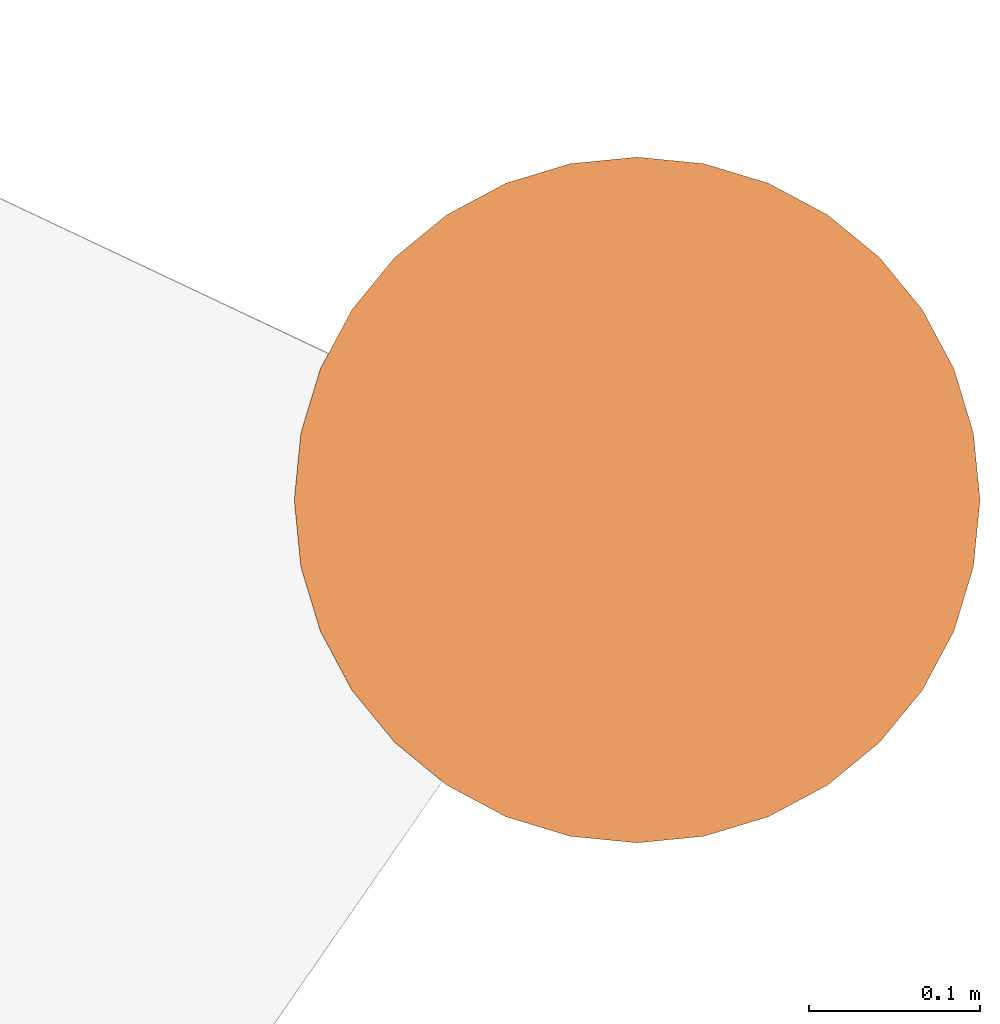
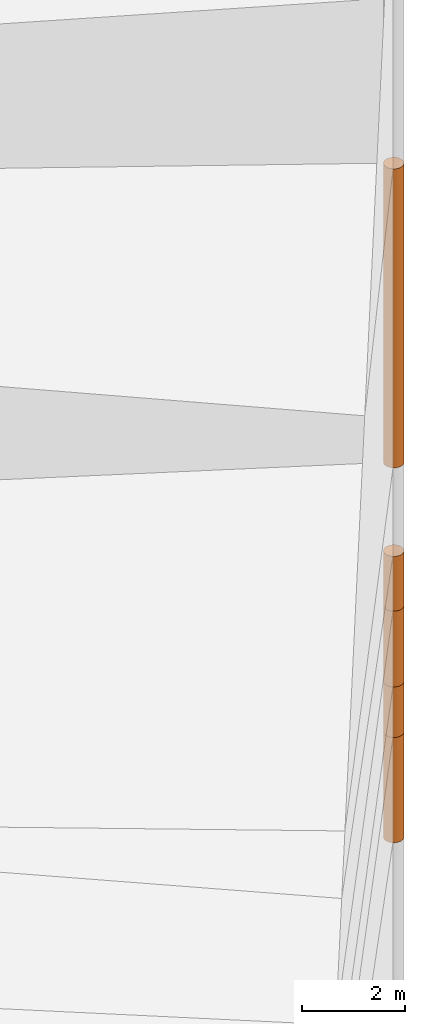
# One storey, part 19 of 24: 5 geographic elements.
"""IFC4 building model written with IfcOpenShell, lengths in metres."""

from ifc_helpers import new_model, entity, si_unit, converted_unit, frame, origin_with_axes, origin_2d_with_axis, place, context, subcontext, project, spatial, polygons, element, save


model = new_model("IFC4")

# Units and contexts
model_context = context("Model", 3, precision=1e-05, world=origin_with_axes())
plan_context = context("Plan", 2, precision=1e-05, world=origin_2d_with_axis())
body_context = subcontext(model_context, "Body", "Model", "MODEL_VIEW")
ifc_project = project(units=[converted_unit("PLANEANGLEUNIT", "degree", entity("IfcReal", 0.0174532925199433), si_unit("PLANEANGLEUNIT", "RADIAN"), dimensions=[0, 0, 0, 0, 0, 0, 0]), si_unit("AREAUNIT", "SQUARE_METRE"), si_unit("VOLUMEUNIT", "CUBIC_METRE"), si_unit("LENGTHUNIT", "METRE")], contexts=[model_context, plan_context])

# Site, building, storey
site_placement = place(None, origin_with_axes())
site = spatial("IfcSite", under=ifc_project, at=site_placement)
building_placement = place(site_placement, origin_with_axes())
building = spatial("IfcBuilding", under=site, at=building_placement, Name="Building")
storey_placement = place(building_placement, origin_with_axes())
storey = spatial("IfcBuildingStorey", under=building, at=storey_placement, Name="Storey")

# Geographic elements
geographic_element_1_placement = place(storey_placement, frame((50.0999984741211, 76.4000015258789, -8.74999904632568), z_axis=(0.0, 0.0, 1.0), x_axis=(1.0, 0.0, 0.0)))
element("IfcGeographicElement", 1, at=geographic_element_1_placement, inside=storey, PredefinedType="NOTDEFINED", context=body_context, shape_type="Tessellation", body=[
    polygons([(0.0, 0.0, -1.24999988079071), (0.0390180610120296, 0.196157038211823, -1.24999988079071), (0.0, 0.199999988079071, -1.24999988079071), (0.0, 0.0, 1.24999988079071), (0.0, 0.199999988079071, 1.24999988079071), (0.0390180610120296, 0.196157038211823, 1.24999988079071), (0.0765366926789284, 0.18477588891983, -1.24999988079071), (0.0765366926789284, 0.18477588891983, 1.24999988079071), (0.111114047467709, 0.166293919086456, -1.24999988079071), (0.111114047467709, 0.166293919086456, 1.24999988079071), (0.141421362757683, 0.141421362757683, -1.24999988079071), (0.141421362757683, 0.141421362757683, 1.24999988079071), (0.166293919086456, 0.111114047467709, -1.24999988079071), (0.166293919086456, 0.111114047467709, 1.24999988079071), (0.18477588891983, 0.0765366926789284, -1.24999988079071), (0.18477588891983, 0.0765366926789284, 1.24999988079071), (0.196157038211823, 0.0390180610120296, -1.24999988079071), (0.196157038211823, 0.0390180610120296, 1.24999988079071), (0.199999988079071, 0.0, -1.24999988079071), (0.199999988079071, 0.0, 1.24999988079071), (0.196157038211823, -0.0390180610120296, -1.24999988079071), (0.196157038211823, -0.0390180610120296, 1.24999988079071), (0.18477588891983, -0.0765366926789284, -1.24999988079071), (0.18477588891983, -0.0765366926789284, 1.24999988079071), (0.166293919086456, -0.111114047467709, -1.24999988079071), (0.166293919086456, -0.111114047467709, 1.24999988079071), (0.141421362757683, -0.141421362757683, -1.24999988079071), (0.141421362757683, -0.141421362757683, 1.24999988079071), (0.111114047467709, -0.166293919086456, -1.24999988079071), (0.111114047467709, -0.166293919086456, 1.24999988079071), (0.0765366926789284, -0.18477588891983, -1.24999988079071), (0.0765366926789284, -0.18477588891983, 1.24999988079071), (0.0390180610120296, -0.196157038211823, -1.24999988079071), (0.0390180610120296, -0.196157038211823, 1.24999988079071), (0.0, -0.199999988079071, -1.24999988079071), (0.0, -0.199999988079071, 1.24999988079071), (-0.0390180610120296, -0.196157038211823, -1.24999988079071), (-0.0390180610120296, -0.196157038211823, 1.24999988079071), (-0.0765366926789284, -0.18477588891983, -1.24999988079071), (-0.0765366926789284, -0.18477588891983, 1.24999988079071), (-0.111114047467709, -0.166293919086456, -1.24999988079071), (-0.111114047467709, -0.166293919086456, 1.24999988079071), (-0.141421362757683, -0.141421362757683, -1.24999988079071), (-0.141421362757683, -0.141421362757683, 1.24999988079071), (-0.166293919086456, -0.111114047467709, -1.24999988079071), (-0.166293919086456, -0.111114047467709, 1.24999988079071), (-0.18477588891983, -0.0765366926789284, -1.24999988079071), (-0.18477588891983, -0.0765366926789284, 1.24999988079071), (-0.196157038211823, -0.0390180610120296, -1.24999988079071), (-0.196157038211823, -0.0390180610120296, 1.24999988079071), (-0.199999988079071, 0.0, -1.24999988079071), (-0.199999988079071, 0.0, 1.24999988079071), (-0.196157038211823, 0.0390180610120296, -1.24999988079071), (-0.196157038211823, 0.0390180610120296, 1.24999988079071), (-0.18477588891983, 0.0765366926789284, -1.24999988079071), (-0.18477588891983, 0.0765366926789284, 1.24999988079071), (-0.166293919086456, 0.111114047467709, -1.24999988079071), (-0.166293919086456, 0.111114047467709, 1.24999988079071), (-0.141421362757683, 0.141421362757683, -1.24999988079071), (-0.141421362757683, 0.141421362757683, 1.24999988079071), (-0.111114047467709, 0.166293919086456, -1.24999988079071), (-0.111114047467709, 0.166293919086456, 1.24999988079071), (-0.0765366926789284, 0.18477588891983, -1.24999988079071), (-0.0765366926789284, 0.18477588891983, 1.24999988079071), (-0.0390180610120296, 0.196157038211823, -1.24999988079071), (-0.0390180610120296, 0.196157038211823, 1.24999988079071)], [[[3, 2, 1]], [[6, 5, 4]], [[62, 64, 63, 61]], [[2, 7, 1]], [[8, 6, 4]], [[30, 32, 31, 29]], [[7, 9, 1]], [[10, 8, 4]], [[10, 12, 11, 9]], [[9, 11, 1]], [[12, 10, 4]], [[11, 13, 1]], [[12, 4, 14]], [[66, 5, 3, 65]], [[1, 13, 15]], [[4, 16, 14]], [[42, 44, 43, 41]], [[1, 15, 17]], [[16, 4, 18]], [[48, 50, 49, 47]], [[1, 17, 19]], [[4, 20, 18]], [[16, 18, 17, 15]], [[1, 19, 21]], [[4, 22, 20]], [[50, 52, 51, 49]], [[1, 21, 23]], [[22, 4, 24]], [[54, 56, 55, 53]], [[1, 23, 25]], [[4, 26, 24]], [[56, 58, 57, 55]], [[1, 25, 27]], [[26, 4, 28]], [[58, 60, 59, 57]], [[1, 27, 29]], [[28, 4, 30]], [[60, 62, 61, 59]], [[1, 29, 31]], [[4, 32, 30]], [[64, 66, 65, 63]], [[1, 31, 33]], [[4, 34, 32]], [[6, 8, 7, 2]], [[1, 33, 35]], [[4, 36, 34]], [[8, 10, 9, 7]], [[1, 35, 37]], [[4, 38, 36]], [[32, 34, 33, 31]], [[1, 37, 39]], [[4, 40, 38]], [[36, 38, 37, 35]], [[1, 39, 41]], [[4, 42, 40]], [[46, 48, 47, 45]], [[43, 1, 41]], [[4, 44, 42]], [[34, 36, 35, 33]], [[45, 1, 43]], [[4, 46, 44]], [[14, 16, 15, 13]], [[45, 47, 1]], [[48, 46, 4]], [[44, 46, 45, 43]], [[49, 1, 47]], [[4, 50, 48]], [[40, 42, 41, 39]], [[49, 51, 1]], [[52, 50, 4]], [[18, 20, 19, 17]], [[51, 53, 1]], [[54, 52, 4]], [[20, 22, 21, 19]], [[55, 1, 53]], [[4, 56, 54]], [[52, 54, 53, 51]], [[55, 57, 1]], [[58, 56, 4]], [[22, 24, 23, 21]], [[59, 1, 57]], [[60, 58, 4]], [[24, 26, 25, 23]], [[59, 61, 1]], [[62, 60, 4]], [[26, 28, 27, 25]], [[61, 63, 1]], [[64, 62, 4]], [[28, 30, 29, 27]], [[63, 65, 1]], [[66, 64, 4]], [[5, 6, 2, 3]], [[65, 3, 1]], [[5, 66, 4]], [[38, 40, 39, 37]], [[12, 14, 13, 11]]]),
])
geographic_element_2_placement = place(storey_placement, frame((50.0999984741211, 76.4000015258789, -6.89999914169312), z_axis=(0.0, 0.0, 1.0), x_axis=(1.0, 0.0, 0.0)))
element("IfcGeographicElement", 2, at=geographic_element_2_placement, inside=storey, PredefinedType="NOTDEFINED", context=body_context, shape_type="Tessellation", body=[
    polygons([(0.0, 0.0, -0.600000023841858), (0.0390180610120296, 0.196157038211823, -0.600000023841858), (0.0, 0.199999988079071, -0.600000023841858), (0.0, 0.0, 0.600000023841858), (0.0, 0.199999988079071, 0.600000023841858), (0.0390180610120296, 0.196157038211823, 0.600000023841858), (0.0765366926789284, 0.18477588891983, -0.600000023841858), (0.0765366926789284, 0.18477588891983, 0.600000023841858), (0.111114047467709, 0.166293919086456, -0.600000023841858), (0.111114047467709, 0.166293919086456, 0.600000023841858), (0.141421362757683, 0.141421362757683, -0.600000023841858), (0.141421362757683, 0.141421362757683, 0.600000023841858), (0.166293919086456, 0.111114047467709, -0.600000023841858), (0.166293919086456, 0.111114047467709, 0.600000023841858), (0.18477588891983, 0.0765366926789284, -0.600000023841858), (0.18477588891983, 0.0765366926789284, 0.600000023841858), (0.196157038211823, 0.0390180610120296, -0.600000023841858), (0.196157038211823, 0.0390180610120296, 0.600000023841858), (0.199999988079071, 0.0, -0.600000023841858), (0.199999988079071, 0.0, 0.600000023841858), (0.196157038211823, -0.0390180610120296, -0.600000023841858), (0.196157038211823, -0.0390180610120296, 0.600000023841858), (0.18477588891983, -0.0765366926789284, -0.600000023841858), (0.18477588891983, -0.0765366926789284, 0.600000023841858), (0.166293919086456, -0.111114047467709, -0.600000023841858), (0.166293919086456, -0.111114047467709, 0.600000023841858), (0.141421362757683, -0.141421362757683, -0.600000023841858), (0.141421362757683, -0.141421362757683, 0.600000023841858), (0.111114047467709, -0.166293919086456, -0.600000023841858), (0.111114047467709, -0.166293919086456, 0.600000023841858), (0.0765366926789284, -0.18477588891983, -0.600000023841858), (0.0765366926789284, -0.18477588891983, 0.600000023841858), (0.0390180610120296, -0.196157038211823, -0.600000023841858), (0.0390180610120296, -0.196157038211823, 0.600000023841858), (0.0, -0.199999988079071, -0.600000023841858), (0.0, -0.199999988079071, 0.600000023841858), (-0.0390180610120296, -0.196157038211823, -0.600000023841858), (-0.0390180610120296, -0.196157038211823, 0.600000023841858), (-0.0765366926789284, -0.18477588891983, -0.600000023841858), (-0.0765366926789284, -0.18477588891983, 0.600000023841858), (-0.111114047467709, -0.166293919086456, -0.600000023841858), (-0.111114047467709, -0.166293919086456, 0.600000023841858), (-0.141421362757683, -0.141421362757683, -0.600000023841858), (-0.141421362757683, -0.141421362757683, 0.600000023841858), (-0.166293919086456, -0.111114047467709, -0.600000023841858), (-0.166293919086456, -0.111114047467709, 0.600000023841858), (-0.18477588891983, -0.0765366926789284, -0.600000023841858), (-0.18477588891983, -0.0765366926789284, 0.600000023841858), (-0.196157038211823, -0.0390180610120296, -0.600000023841858), (-0.196157038211823, -0.0390180610120296, 0.600000023841858), (-0.199999988079071, 0.0, -0.600000023841858), (-0.199999988079071, 0.0, 0.600000023841858), (-0.196157038211823, 0.0390180610120296, -0.600000023841858), (-0.196157038211823, 0.0390180610120296, 0.600000023841858), (-0.18477588891983, 0.0765366926789284, -0.600000023841858), (-0.18477588891983, 0.0765366926789284, 0.600000023841858), (-0.166293919086456, 0.111114047467709, -0.600000023841858), (-0.166293919086456, 0.111114047467709, 0.600000023841858), (-0.141421362757683, 0.141421362757683, -0.600000023841858), (-0.141421362757683, 0.141421362757683, 0.600000023841858), (-0.111114047467709, 0.166293919086456, -0.600000023841858), (-0.111114047467709, 0.166293919086456, 0.600000023841858), (-0.0765366926789284, 0.18477588891983, -0.600000023841858), (-0.0765366926789284, 0.18477588891983, 0.600000023841858), (-0.0390180610120296, 0.196157038211823, -0.600000023841858), (-0.0390180610120296, 0.196157038211823, 0.600000023841858)], [[[3, 2, 1]], [[6, 5, 4]], [[28, 30, 29, 27]], [[2, 7, 1]], [[8, 6, 4]], [[36, 38, 37, 35]], [[7, 9, 1]], [[10, 8, 4]], [[56, 58, 57, 55]], [[9, 11, 1]], [[12, 10, 4]], [[58, 60, 59, 57]], [[11, 13, 1]], [[12, 4, 14]], [[54, 56, 55, 53]], [[1, 13, 15]], [[14, 4, 16]], [[10, 12, 11, 9]], [[1, 15, 17]], [[16, 4, 18]], [[60, 62, 61, 59]], [[1, 17, 19]], [[18, 4, 20]], [[16, 18, 17, 15]], [[1, 19, 21]], [[20, 4, 22]], [[18, 20, 19, 17]], [[1, 21, 23]], [[22, 4, 24]], [[20, 22, 21, 19]], [[1, 23, 25]], [[24, 4, 26]], [[22, 24, 23, 21]], [[27, 1, 25]], [[26, 4, 28]], [[24, 26, 25, 23]], [[1, 27, 29]], [[28, 4, 30]], [[62, 64, 63, 61]], [[1, 29, 31]], [[4, 32, 30]], [[64, 66, 65, 63]], [[1, 31, 33]], [[4, 34, 32]], [[30, 32, 31, 29]], [[1, 33, 35]], [[4, 36, 34]], [[8, 10, 9, 7]], [[1, 35, 37]], [[4, 38, 36]], [[32, 34, 33, 31]], [[1, 37, 39]], [[4, 40, 38]], [[6, 8, 7, 2]], [[1, 39, 41]], [[4, 42, 40]], [[38, 40, 39, 37]], [[43, 1, 41]], [[4, 44, 42]], [[40, 42, 41, 39]], [[45, 1, 43]], [[46, 44, 4]], [[42, 44, 43, 41]], [[47, 1, 45]], [[4, 48, 46]], [[44, 46, 45, 43]], [[49, 1, 47]], [[4, 50, 48]], [[46, 48, 47, 45]], [[51, 1, 49]], [[4, 52, 50]], [[48, 50, 49, 47]], [[53, 1, 51]], [[4, 54, 52]], [[66, 5, 3, 65]], [[55, 1, 53]], [[4, 56, 54]], [[52, 54, 53, 51]], [[57, 1, 55]], [[4, 58, 56]], [[57, 59, 1]], [[60, 58, 4]], [[34, 36, 35, 33]], [[59, 61, 1]], [[62, 60, 4]], [[14, 16, 15, 13]], [[61, 63, 1]], [[64, 62, 4]], [[26, 28, 27, 25]], [[63, 65, 1]], [[66, 64, 4]], [[5, 6, 2, 3]], [[65, 3, 1]], [[5, 66, 4]], [[50, 52, 51, 49]], [[12, 14, 13, 11]]]),
])
geographic_element_3_placement = place(storey_placement, frame((50.0999984741211, 76.4000015258789, -5.39999914169312), z_axis=(0.0, 0.0, 1.0), x_axis=(1.0, 0.0, 0.0)))
element("IfcGeographicElement", 3, at=geographic_element_3_placement, inside=storey, PredefinedType="NOTDEFINED", context=body_context, shape_type="Tessellation", body=[
    polygons([(0.0, 0.0, -0.899999916553497), (0.0390180610120296, 0.196157038211823, -0.899999916553497), (0.0, 0.199999988079071, -0.899999916553497), (0.0, 0.0, 0.899999916553497), (0.0, 0.199999988079071, 0.899999916553497), (0.0390180610120296, 0.196157038211823, 0.899999916553497), (0.0765366926789284, 0.18477588891983, -0.899999916553497), (0.0765366926789284, 0.18477588891983, 0.899999916553497), (0.111114047467709, 0.166293919086456, -0.899999916553497), (0.111114047467709, 0.166293919086456, 0.899999916553497), (0.141421362757683, 0.141421362757683, -0.899999916553497), (0.141421362757683, 0.141421362757683, 0.899999916553497), (0.166293919086456, 0.111114047467709, -0.899999916553497), (0.166293919086456, 0.111114047467709, 0.899999916553497), (0.18477588891983, 0.0765366926789284, -0.899999916553497), (0.18477588891983, 0.0765366926789284, 0.899999916553497), (0.196157038211823, 0.0390180610120296, -0.899999916553497), (0.196157038211823, 0.0390180610120296, 0.899999916553497), (0.199999988079071, 0.0, -0.899999916553497), (0.199999988079071, 0.0, 0.899999916553497), (0.196157038211823, -0.0390180610120296, -0.899999916553497), (0.196157038211823, -0.0390180610120296, 0.899999916553497), (0.18477588891983, -0.0765366926789284, -0.899999916553497), (0.18477588891983, -0.0765366926789284, 0.899999916553497), (0.166293919086456, -0.111114047467709, -0.899999916553497), (0.166293919086456, -0.111114047467709, 0.899999916553497), (0.141421362757683, -0.141421362757683, -0.899999916553497), (0.141421362757683, -0.141421362757683, 0.899999916553497), (0.111114047467709, -0.166293919086456, -0.899999916553497), (0.111114047467709, -0.166293919086456, 0.899999916553497), (0.0765366926789284, -0.18477588891983, -0.899999916553497), (0.0765366926789284, -0.18477588891983, 0.899999916553497), (0.0390180610120296, -0.196157038211823, -0.899999916553497), (0.0390180610120296, -0.196157038211823, 0.899999916553497), (0.0, -0.199999988079071, -0.899999916553497), (0.0, -0.199999988079071, 0.899999916553497), (-0.0390180610120296, -0.196157038211823, -0.899999916553497), (-0.0390180610120296, -0.196157038211823, 0.899999916553497), (-0.0765366926789284, -0.18477588891983, -0.899999916553497), (-0.0765366926789284, -0.18477588891983, 0.899999916553497), (-0.111114047467709, -0.166293919086456, -0.899999916553497), (-0.111114047467709, -0.166293919086456, 0.899999916553497), (-0.141421362757683, -0.141421362757683, -0.899999916553497), (-0.141421362757683, -0.141421362757683, 0.899999916553497), (-0.166293919086456, -0.111114047467709, -0.899999916553497), (-0.166293919086456, -0.111114047467709, 0.899999916553497), (-0.18477588891983, -0.0765366926789284, -0.899999916553497), (-0.18477588891983, -0.0765366926789284, 0.899999916553497), (-0.196157038211823, -0.0390180610120296, -0.899999916553497), (-0.196157038211823, -0.0390180610120296, 0.899999916553497), (-0.199999988079071, 0.0, -0.899999916553497), (-0.199999988079071, 0.0, 0.899999916553497), (-0.196157038211823, 0.0390180610120296, -0.899999916553497), (-0.196157038211823, 0.0390180610120296, 0.899999916553497), (-0.18477588891983, 0.0765366926789284, -0.899999916553497), (-0.18477588891983, 0.0765366926789284, 0.899999916553497), (-0.166293919086456, 0.111114047467709, -0.899999916553497), (-0.166293919086456, 0.111114047467709, 0.899999916553497), (-0.141421362757683, 0.141421362757683, -0.899999916553497), (-0.141421362757683, 0.141421362757683, 0.899999916553497), (-0.111114047467709, 0.166293919086456, -0.899999916553497), (-0.111114047467709, 0.166293919086456, 0.899999916553497), (-0.0765366926789284, 0.18477588891983, -0.899999916553497), (-0.0765366926789284, 0.18477588891983, 0.899999916553497), (-0.0390180610120296, 0.196157038211823, -0.899999916553497), (-0.0390180610120296, 0.196157038211823, 0.899999916553497)], [[[3, 2, 1]], [[6, 5, 4]], [[32, 34, 33, 31]], [[2, 7, 1]], [[8, 6, 4]], [[64, 66, 65, 63]], [[7, 9, 1]], [[10, 8, 4]], [[9, 11, 1]], [[12, 10, 4]], [[40, 42, 41, 39]], [[1, 11, 13]], [[12, 4, 14]], [[10, 12, 11, 9]], [[1, 13, 15]], [[4, 16, 14]], [[12, 14, 13, 11]], [[1, 15, 17]], [[16, 4, 18]], [[18, 20, 19, 17]], [[1, 17, 19]], [[4, 20, 18]], [[20, 22, 21, 19]], [[1, 19, 21]], [[4, 22, 20]], [[22, 24, 23, 21]], [[1, 21, 23]], [[22, 4, 24]], [[54, 56, 55, 53]], [[1, 23, 25]], [[4, 26, 24]], [[56, 58, 57, 55]], [[1, 25, 27]], [[4, 28, 26]], [[24, 26, 25, 23]], [[1, 27, 29]], [[28, 4, 30]], [[26, 28, 27, 25]], [[1, 29, 31]], [[4, 32, 30]], [[46, 48, 47, 45]], [[1, 31, 33]], [[4, 34, 32]], [[36, 38, 37, 35]], [[1, 33, 35]], [[4, 36, 34]], [[42, 44, 43, 41]], [[1, 35, 37]], [[4, 38, 36]], [[38, 40, 39, 37]], [[1, 37, 39]], [[4, 40, 38]], [[34, 36, 35, 33]], [[1, 39, 41]], [[4, 42, 40]], [[8, 10, 9, 7]], [[43, 1, 41]], [[4, 44, 42]], [[44, 46, 45, 43]], [[43, 45, 1]], [[4, 46, 44]], [[30, 32, 31, 29]], [[45, 47, 1]], [[48, 46, 4]], [[28, 30, 29, 27]], [[49, 1, 47]], [[4, 50, 48]], [[5, 6, 2, 3]], [[49, 51, 1]], [[52, 50, 4]], [[48, 50, 49, 47]], [[51, 53, 1]], [[54, 52, 4]], [[50, 52, 51, 49]], [[55, 1, 53]], [[4, 56, 54]], [[52, 54, 53, 51]], [[55, 57, 1]], [[58, 56, 4]], [[58, 60, 59, 57]], [[59, 1, 57]], [[60, 58, 4]], [[60, 62, 61, 59]], [[59, 61, 1]], [[62, 60, 4]], [[62, 64, 63, 61]], [[61, 63, 1]], [[64, 62, 4]], [[14, 16, 15, 13]], [[63, 65, 1]], [[66, 64, 4]], [[16, 18, 17, 15]], [[65, 3, 1]], [[5, 66, 4]], [[6, 8, 7, 2]], [[66, 5, 3, 65]]]),
])
geographic_element_4_placement = place(storey_placement, frame((50.0999984741211, 76.4000015258789, -3.84999895095825), z_axis=(0.0, 0.0, 1.0), x_axis=(1.0, 0.0, 0.0)))
element("IfcGeographicElement", 4, at=geographic_element_4_placement, inside=storey, PredefinedType="NOTDEFINED", context=body_context, shape_type="Tessellation", body=[
    polygons([(0.0, 0.0, -0.649999916553497), (0.0390180610120296, 0.196157038211823, -0.649999916553497), (0.0, 0.199999988079071, -0.649999916553497), (0.0, 0.0, 0.649999916553497), (0.0, 0.199999988079071, 0.649999916553497), (0.0390180610120296, 0.196157038211823, 0.649999916553497), (0.0765366926789284, 0.18477588891983, -0.649999916553497), (0.0765366926789284, 0.18477588891983, 0.649999916553497), (0.111114047467709, 0.166293919086456, -0.649999916553497), (0.111114047467709, 0.166293919086456, 0.649999916553497), (0.141421362757683, 0.141421362757683, -0.649999916553497), (0.141421362757683, 0.141421362757683, 0.649999916553497), (0.166293919086456, 0.111114047467709, -0.649999916553497), (0.166293919086456, 0.111114047467709, 0.649999916553497), (0.18477588891983, 0.0765366926789284, -0.649999916553497), (0.18477588891983, 0.0765366926789284, 0.649999916553497), (0.196157038211823, 0.0390180610120296, -0.649999916553497), (0.196157038211823, 0.0390180610120296, 0.649999916553497), (0.199999988079071, 0.0, -0.649999916553497), (0.199999988079071, 0.0, 0.649999916553497), (0.196157038211823, -0.0390180610120296, -0.649999916553497), (0.196157038211823, -0.0390180610120296, 0.649999916553497), (0.18477588891983, -0.0765366926789284, -0.649999916553497), (0.18477588891983, -0.0765366926789284, 0.649999916553497), (0.166293919086456, -0.111114047467709, -0.649999916553497), (0.166293919086456, -0.111114047467709, 0.649999916553497), (0.141421362757683, -0.141421362757683, -0.649999916553497), (0.141421362757683, -0.141421362757683, 0.649999916553497), (0.111114047467709, -0.166293919086456, -0.649999916553497), (0.111114047467709, -0.166293919086456, 0.649999916553497), (0.0765366926789284, -0.18477588891983, -0.649999916553497), (0.0765366926789284, -0.18477588891983, 0.649999916553497), (0.0390180610120296, -0.196157038211823, -0.649999916553497), (0.0390180610120296, -0.196157038211823, 0.649999916553497), (0.0, -0.199999988079071, -0.649999916553497), (0.0, -0.199999988079071, 0.649999916553497), (-0.0390180610120296, -0.196157038211823, -0.649999916553497), (-0.0390180610120296, -0.196157038211823, 0.649999916553497), (-0.0765366926789284, -0.18477588891983, -0.649999916553497), (-0.0765366926789284, -0.18477588891983, 0.649999916553497), (-0.111114047467709, -0.166293919086456, -0.649999916553497), (-0.111114047467709, -0.166293919086456, 0.649999916553497), (-0.141421362757683, -0.141421362757683, -0.649999916553497), (-0.141421362757683, -0.141421362757683, 0.649999916553497), (-0.166293919086456, -0.111114047467709, -0.649999916553497), (-0.166293919086456, -0.111114047467709, 0.649999916553497), (-0.18477588891983, -0.0765366926789284, -0.649999916553497), (-0.18477588891983, -0.0765366926789284, 0.649999916553497), (-0.196157038211823, -0.0390180610120296, -0.649999916553497), (-0.196157038211823, -0.0390180610120296, 0.649999916553497), (-0.199999988079071, 0.0, -0.649999916553497), (-0.199999988079071, 0.0, 0.649999916553497), (-0.196157038211823, 0.0390180610120296, -0.649999916553497), (-0.196157038211823, 0.0390180610120296, 0.649999916553497), (-0.18477588891983, 0.0765366926789284, -0.649999916553497), (-0.18477588891983, 0.0765366926789284, 0.649999916553497), (-0.166293919086456, 0.111114047467709, -0.649999916553497), (-0.166293919086456, 0.111114047467709, 0.649999916553497), (-0.141421362757683, 0.141421362757683, -0.649999916553497), (-0.141421362757683, 0.141421362757683, 0.649999916553497), (-0.111114047467709, 0.166293919086456, -0.649999916553497), (-0.111114047467709, 0.166293919086456, 0.649999916553497), (-0.0765366926789284, 0.18477588891983, -0.649999916553497), (-0.0765366926789284, 0.18477588891983, 0.649999916553497), (-0.0390180610120296, 0.196157038211823, -0.649999916553497), (-0.0390180610120296, 0.196157038211823, 0.649999916553497)], [[[3, 2, 1]], [[6, 5, 4]], [[32, 34, 33, 31]], [[2, 7, 1]], [[8, 6, 4]], [[64, 66, 65, 63]], [[7, 9, 1]], [[10, 8, 4]], [[9, 11, 1]], [[12, 10, 4]], [[40, 42, 41, 39]], [[1, 11, 13]], [[12, 4, 14]], [[10, 12, 11, 9]], [[1, 13, 15]], [[4, 16, 14]], [[12, 14, 13, 11]], [[1, 15, 17]], [[4, 18, 16]], [[18, 20, 19, 17]], [[1, 17, 19]], [[4, 20, 18]], [[20, 22, 21, 19]], [[1, 19, 21]], [[4, 22, 20]], [[22, 24, 23, 21]], [[1, 21, 23]], [[22, 4, 24]], [[54, 56, 55, 53]], [[1, 23, 25]], [[24, 4, 26]], [[56, 58, 57, 55]], [[1, 25, 27]], [[4, 28, 26]], [[24, 26, 25, 23]], [[1, 27, 29]], [[28, 4, 30]], [[26, 28, 27, 25]], [[1, 29, 31]], [[4, 32, 30]], [[46, 48, 47, 45]], [[1, 31, 33]], [[4, 34, 32]], [[36, 38, 37, 35]], [[1, 33, 35]], [[4, 36, 34]], [[42, 44, 43, 41]], [[1, 35, 37]], [[4, 38, 36]], [[38, 40, 39, 37]], [[1, 37, 39]], [[4, 40, 38]], [[34, 36, 35, 33]], [[1, 39, 41]], [[4, 42, 40]], [[8, 10, 9, 7]], [[43, 1, 41]], [[4, 44, 42]], [[44, 46, 45, 43]], [[43, 45, 1]], [[4, 46, 44]], [[30, 32, 31, 29]], [[47, 1, 45]], [[48, 46, 4]], [[28, 30, 29, 27]], [[49, 1, 47]], [[50, 48, 4]], [[5, 6, 2, 3]], [[49, 51, 1]], [[52, 50, 4]], [[48, 50, 49, 47]], [[51, 53, 1]], [[54, 52, 4]], [[50, 52, 51, 49]], [[53, 55, 1]], [[4, 56, 54]], [[52, 54, 53, 51]], [[55, 57, 1]], [[4, 58, 56]], [[58, 60, 59, 57]], [[59, 1, 57]], [[60, 58, 4]], [[60, 62, 61, 59]], [[59, 61, 1]], [[62, 60, 4]], [[62, 64, 63, 61]], [[61, 63, 1]], [[64, 62, 4]], [[14, 16, 15, 13]], [[63, 65, 1]], [[66, 64, 4]], [[16, 18, 17, 15]], [[65, 3, 1]], [[5, 66, 4]], [[6, 8, 7, 2]], [[66, 5, 3, 65]]]),
])
geographic_element_5_placement = place(storey_placement, frame((50.0999984741211, 76.4000015258789, 2.45000076293945), z_axis=(0.0, 0.0, 1.0), x_axis=(1.0, 0.0, 0.0)))
element("IfcGeographicElement", 5, at=geographic_element_5_placement, inside=storey, PredefinedType="NOTDEFINED", context=body_context, shape_type="Tessellation", body=[
    polygons([(0.0, 0.0, -3.54999971389771), (0.0390180610120296, 0.196157038211823, -3.54999971389771), (0.0, 0.199999988079071, -3.54999971389771), (0.0, 0.0, 3.54999971389771), (0.0, 0.199999988079071, 3.54999971389771), (0.0390180610120296, 0.196157038211823, 3.54999971389771), (0.0765366926789284, 0.18477588891983, -3.54999971389771), (0.0765366926789284, 0.18477588891983, 3.54999971389771), (0.111114047467709, 0.166293919086456, -3.54999971389771), (0.111114047467709, 0.166293919086456, 3.54999971389771), (0.141421362757683, 0.141421362757683, -3.54999971389771), (0.141421362757683, 0.141421362757683, 3.54999971389771), (0.166293919086456, 0.111114047467709, -3.54999971389771), (0.166293919086456, 0.111114047467709, 3.54999971389771), (0.18477588891983, 0.0765366926789284, -3.54999971389771), (0.18477588891983, 0.0765366926789284, 3.54999971389771), (0.196157038211823, 0.0390180610120296, -3.54999971389771), (0.196157038211823, 0.0390180610120296, 3.54999971389771), (0.199999988079071, 0.0, -3.54999971389771), (0.199999988079071, 0.0, 3.54999971389771), (0.196157038211823, -0.0390180610120296, -3.54999971389771), (0.196157038211823, -0.0390180610120296, 3.54999971389771), (0.18477588891983, -0.0765366926789284, -3.54999971389771), (0.18477588891983, -0.0765366926789284, 3.54999971389771), (0.166293919086456, -0.111114047467709, -3.54999971389771), (0.166293919086456, -0.111114047467709, 3.54999971389771), (0.141421362757683, -0.141421362757683, -3.54999971389771), (0.141421362757683, -0.141421362757683, 3.54999971389771), (0.111114047467709, -0.166293919086456, -3.54999971389771), (0.111114047467709, -0.166293919086456, 3.54999971389771), (0.0765366926789284, -0.18477588891983, -3.54999971389771), (0.0765366926789284, -0.18477588891983, 3.54999971389771), (0.0390180610120296, -0.196157038211823, -3.54999971389771), (0.0390180610120296, -0.196157038211823, 3.54999971389771), (0.0, -0.199999988079071, -3.54999971389771), (0.0, -0.199999988079071, 3.54999971389771), (-0.0390180610120296, -0.196157038211823, -3.54999971389771), (-0.0390180610120296, -0.196157038211823, 3.54999971389771), (-0.0765366926789284, -0.18477588891983, -3.54999971389771), (-0.0765366926789284, -0.18477588891983, 3.54999971389771), (-0.111114047467709, -0.166293919086456, -3.54999971389771), (-0.111114047467709, -0.166293919086456, 3.54999971389771), (-0.141421362757683, -0.141421362757683, -3.54999971389771), (-0.141421362757683, -0.141421362757683, 3.54999971389771), (-0.166293919086456, -0.111114047467709, -3.54999971389771), (-0.166293919086456, -0.111114047467709, 3.54999971389771), (-0.18477588891983, -0.0765366926789284, -3.54999971389771), (-0.18477588891983, -0.0765366926789284, 3.54999971389771), (-0.196157038211823, -0.0390180610120296, -3.54999971389771), (-0.196157038211823, -0.0390180610120296, 3.54999971389771), (-0.199999988079071, 0.0, -3.54999971389771), (-0.199999988079071, 0.0, 3.54999971389771), (-0.196157038211823, 0.0390180610120296, -3.54999971389771), (-0.196157038211823, 0.0390180610120296, 3.54999971389771), (-0.18477588891983, 0.0765366926789284, -3.54999971389771), (-0.18477588891983, 0.0765366926789284, 3.54999971389771), (-0.166293919086456, 0.111114047467709, -3.54999971389771), (-0.166293919086456, 0.111114047467709, 3.54999971389771), (-0.141421362757683, 0.141421362757683, -3.54999971389771), (-0.141421362757683, 0.141421362757683, 3.54999971389771), (-0.111114047467709, 0.166293919086456, -3.54999971389771), (-0.111114047467709, 0.166293919086456, 3.54999971389771), (-0.0765366926789284, 0.18477588891983, -3.54999971389771), (-0.0765366926789284, 0.18477588891983, 3.54999971389771), (-0.0390180610120296, 0.196157038211823, -3.54999971389771), (-0.0390180610120296, 0.196157038211823, 3.54999971389771)], [[[3, 2, 1]], [[6, 5, 4]], [[32, 34, 33, 31]], [[2, 7, 1]], [[8, 6, 4]], [[64, 66, 65, 63]], [[7, 9, 1]], [[10, 8, 4]], [[9, 11, 1]], [[12, 10, 4]], [[40, 42, 41, 39]], [[1, 11, 13]], [[12, 4, 14]], [[10, 12, 11, 9]], [[1, 13, 15]], [[14, 4, 16]], [[12, 14, 13, 11]], [[1, 15, 17]], [[16, 4, 18]], [[18, 20, 19, 17]], [[1, 17, 19]], [[4, 20, 18]], [[20, 22, 21, 19]], [[1, 19, 21]], [[20, 4, 22]], [[22, 24, 23, 21]], [[1, 21, 23]], [[4, 24, 22]], [[54, 56, 55, 53]], [[1, 23, 25]], [[4, 26, 24]], [[56, 58, 57, 55]], [[1, 25, 27]], [[4, 28, 26]], [[24, 26, 25, 23]], [[1, 27, 29]], [[28, 4, 30]], [[26, 28, 27, 25]], [[1, 29, 31]], [[4, 32, 30]], [[46, 48, 47, 45]], [[1, 31, 33]], [[4, 34, 32]], [[36, 38, 37, 35]], [[1, 33, 35]], [[4, 36, 34]], [[42, 44, 43, 41]], [[1, 35, 37]], [[4, 38, 36]], [[38, 40, 39, 37]], [[1, 37, 39]], [[4, 40, 38]], [[34, 36, 35, 33]], [[1, 39, 41]], [[4, 42, 40]], [[8, 10, 9, 7]], [[43, 1, 41]], [[4, 44, 42]], [[44, 46, 45, 43]], [[43, 45, 1]], [[4, 46, 44]], [[30, 32, 31, 29]], [[45, 47, 1]], [[4, 48, 46]], [[28, 30, 29, 27]], [[47, 49, 1]], [[4, 50, 48]], [[5, 6, 2, 3]], [[51, 1, 49]], [[52, 50, 4]], [[48, 50, 49, 47]], [[51, 53, 1]], [[4, 54, 52]], [[50, 52, 51, 49]], [[55, 1, 53]], [[56, 54, 4]], [[52, 54, 53, 51]], [[57, 1, 55]], [[58, 56, 4]], [[58, 60, 59, 57]], [[59, 1, 57]], [[60, 58, 4]], [[60, 62, 61, 59]], [[59, 61, 1]], [[62, 60, 4]], [[62, 64, 63, 61]], [[61, 63, 1]], [[64, 62, 4]], [[14, 16, 15, 13]], [[63, 65, 1]], [[66, 64, 4]], [[16, 18, 17, 15]], [[65, 3, 1]], [[5, 66, 4]], [[6, 8, 7, 2]], [[66, 5, 3, 65]]]),
])

save(model, "model.ifc")
